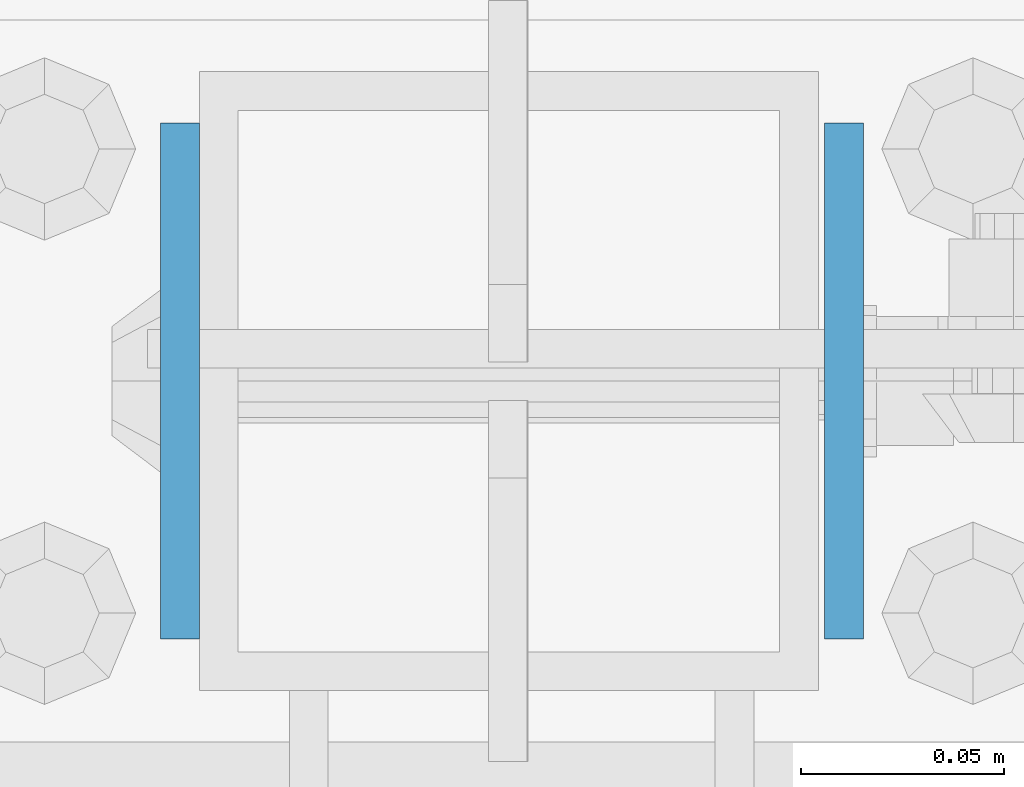
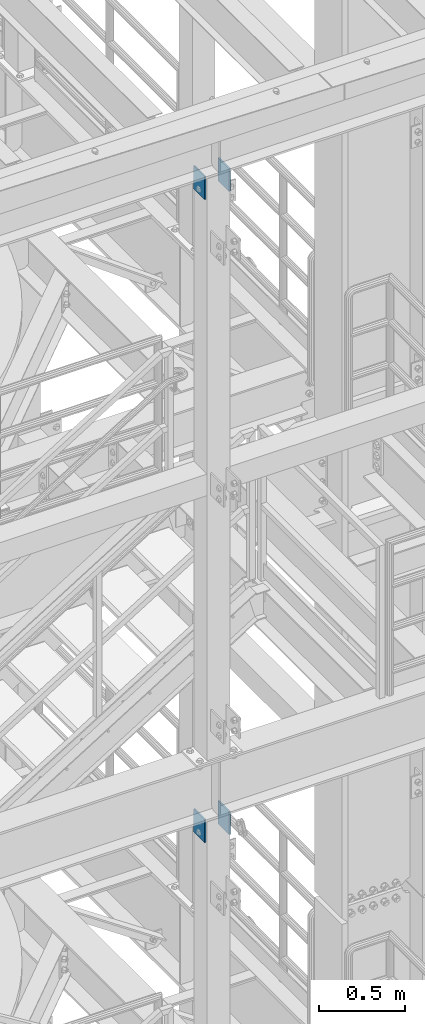
# One storey, part 1145 of 1876: 4 beams, 2 elements without a shape of their own.
"""IFC2X3 building model written with IfcOpenShell, lengths in millimetres."""

from ifc_helpers import new_model, si_unit, frame, origin_with_axes, place, context, subcontext, project, spatial, faceted_brep, material, type_object, element, aggregate, save


model = new_model("IFC2X3")

# Units and contexts
model_context = context("Model", 3, precision=1e-05, world=origin_with_axes())
body_context = subcontext(model_context, "Body", "Model", "MODEL_VIEW")
ifc_project = project(units=[si_unit("LENGTHUNIT", "METRE", prefix="MILLI"), si_unit("AREAUNIT", "SQUARE_METRE"), si_unit("VOLUMEUNIT", "CUBIC_METRE"), si_unit("MASSUNIT", "GRAM", prefix="KILO"), si_unit("TIMEUNIT", "SECOND"), si_unit("PLANEANGLEUNIT", "RADIAN"), si_unit("SOLIDANGLEUNIT", "STERADIAN"), si_unit("THERMODYNAMICTEMPERATUREUNIT", "DEGREE_CELSIUS"), si_unit("LUMINOUSINTENSITYUNIT", "LUMEN")], contexts=[model_context])

# Site, building, storey
site_placement = place(None, origin_with_axes())
site = spatial("IfcSite", under=ifc_project, at=site_placement, CompositionType="ELEMENT")
building_placement = place(site_placement, origin_with_axes())
building = spatial("IfcBuilding", under=site, at=building_placement, Name="Undefined", CompositionType="ELEMENT")
storey_placement = place(building_placement, origin_with_axes())
storey = spatial("IfcBuildingStorey", under=building, at=storey_placement, Name="Undefined", CompositionType="ELEMENT", Elevation=0.0)

# Assembly, beams
assembly_1_placement = place(storey_placement, origin_with_axes())
assembly_1 = element("IfcElementAssembly", 1, at=assembly_1_placement, inside=storey, Name="BEAM", AssemblyPlace="NOTDEFINED", PredefinedType="RIGID_FRAME")
ifc_material = material(Name="STEEL/A36")
beam_type = type_object("IfcBeamType", PredefinedType="NOTDEFINED")
beam_1_placement = place(assembly_1_placement, frame((5162.55, -7048.5, 17491.075), z_axis=(0.0, 0.0, -1.0), x_axis=(0.0, -1.0, 0.0)))
beam_1 = element("IfcBeam", 2, at=beam_1_placement, type_object=beam_type, material=ifc_material, Name="PLATE", context=body_context, shape_type="Brep", body=[
    faceted_brep([(0.0, 4.76249999999982, -82.5499999999993), (0.0, 4.76249999999982, 82.5499999999993), (127.0, 4.76249999999982, 82.5499999999993), (127.0, 4.76249999999982, -82.5499999999993), (0.0, -4.76249999999982, 82.5499999999993), (127.0, -4.76249999999982, 82.5499999999993), (0.0, -4.76249999999982, -82.5499999999993), (127.0, -4.76249999999982, -82.5499999999993)], [[[0, 1, 2, 3]], [[1, 4, 5, 2]], [[4, 6, 7, 5]], [[6, 0, 3, 7]], [[5, 7, 3, 2]], [[6, 4, 1, 0]]]),
])
beam_2_placement = place(assembly_1_placement, frame((4999.0375, -7048.5, 17491.075), z_axis=(0.0, 0.0, -1.0), x_axis=(0.0, -1.0, 0.0)))
beam_2 = element("IfcBeam", 3, at=beam_2_placement, type_object=beam_type, material=ifc_material, Name="PLATE", context=body_context, shape_type="Brep", body=[
    faceted_brep([(0.0, 4.76249999999982, -82.5499999999993), (0.0, 4.76249999999982, 82.5499999999993), (127.0, 4.76249999999982, 82.5499999999993), (127.0, 4.76249999999982, -82.5499999999993), (0.0, -4.76249999999982, 82.5499999999993), (127.0, -4.76249999999982, 82.5499999999993), (0.0, -4.76249999999982, -82.5499999999993), (127.0, -4.76249999999982, -82.5499999999993)], [[[0, 1, 2, 3]], [[1, 4, 5, 2]], [[4, 6, 7, 5]], [[6, 0, 3, 7]], [[5, 7, 3, 2]], [[6, 4, 1, 0]]]),
])
aggregate(assembly_1, [beam_1, beam_2])

assembly_2_placement = place(storey_placement, origin_with_axes())
assembly_2 = element("IfcElementAssembly", 4, at=assembly_2_placement, inside=storey, Name="BEAM", AssemblyPlace="NOTDEFINED", PredefinedType="RIGID_FRAME")
beam_3_placement = place(assembly_2_placement, frame((5162.55, -7048.5, 22063.075), z_axis=(0.0, 0.0, -1.0), x_axis=(0.0, -1.0, 0.0)))
beam_3 = element("IfcBeam", 5, at=beam_3_placement, type_object=beam_type, material=ifc_material, Name="PLATE", context=body_context, shape_type="Brep", body=[
    faceted_brep([(0.0, 4.76249999999982, -82.5499999999993), (0.0, 4.76249999999982, 82.5499999999993), (127.0, 4.76249999999982, 82.5499999999993), (127.0, 4.76249999999982, -82.5499999999993), (0.0, -4.76249999999982, 82.5499999999993), (127.0, -4.76249999999982, 82.5499999999993), (0.0, -4.76249999999982, -82.5499999999993), (127.0, -4.76249999999982, -82.5499999999993)], [[[0, 1, 2, 3]], [[1, 4, 5, 2]], [[4, 6, 7, 5]], [[6, 0, 3, 7]], [[5, 7, 3, 2]], [[6, 4, 1, 0]]]),
])
beam_4_placement = place(assembly_2_placement, frame((4999.0375, -7048.5, 22063.075), z_axis=(0.0, 0.0, -1.0), x_axis=(0.0, -1.0, 0.0)))
beam_4 = element("IfcBeam", 6, at=beam_4_placement, type_object=beam_type, material=ifc_material, Name="PLATE", context=body_context, shape_type="Brep", body=[
    faceted_brep([(0.0, 4.76249999999982, -82.5499999999993), (0.0, 4.76249999999982, 82.5499999999993), (127.0, 4.76249999999982, 82.5499999999993), (127.0, 4.76249999999982, -82.5499999999993), (0.0, -4.76249999999982, 82.5499999999993), (127.0, -4.76249999999982, 82.5499999999993), (0.0, -4.76249999999982, -82.5499999999993), (127.0, -4.76249999999982, -82.5499999999993)], [[[0, 1, 2, 3]], [[1, 4, 5, 2]], [[4, 6, 7, 5]], [[6, 0, 3, 7]], [[5, 7, 3, 2]], [[6, 4, 1, 0]]]),
])
aggregate(assembly_2, [beam_3, beam_4])

save(model, "model.ifc")
